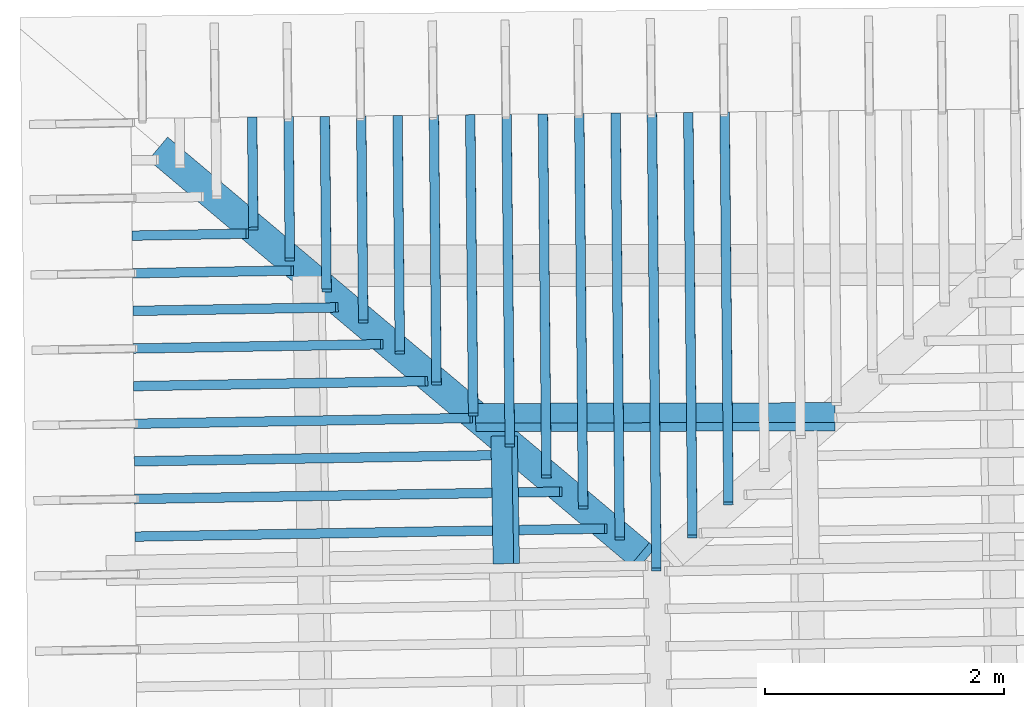
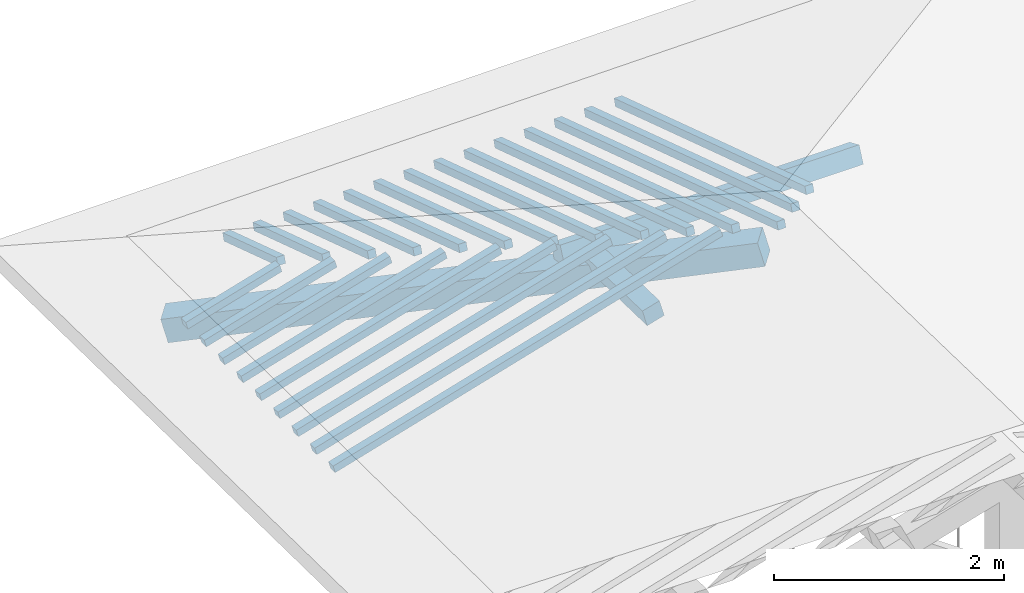
# One storey, part 7 of 19: 24 beams, 2 members, 2 elements without a shape of their own.
"""IFC4 building model written with IfcOpenShell, lengths in metres."""

from ifc_helpers import new_model, entity, si_unit, converted_unit, derived_unit, direction, frame, origin, place, context, subcontext, project, spatial, indexed_curve, outline, extrude, source, transform, mapped, material, type_object, type_shapes, element, aggregate, save


model = new_model("IFC4")

# Units and contexts
model_context = context("Model", 3, precision=1e-05, world=origin(), true_north=direction((6.123233995736766e-17, 1.0)))
body_context = subcontext(model_context, "Body", "Model", "MODEL_VIEW")
ifc_project = project(units=[si_unit("LENGTHUNIT", "METRE"), si_unit("AREAUNIT", "SQUARE_METRE"), si_unit("VOLUMEUNIT", "CUBIC_METRE"), converted_unit("PLANEANGLEUNIT", "DEGREE", entity("IfcPlaneAngleMeasure", 0.017453292519943278), si_unit("PLANEANGLEUNIT", "RADIAN"), dimensions=[0, 0, 0, 0, 0, 0, 0]), derived_unit("THERMALTRANSMITTANCEUNIT", [(si_unit("MASSUNIT", "GRAM", prefix="KILO"), 1), (si_unit("THERMODYNAMICTEMPERATUREUNIT", "KELVIN"), -1), (si_unit("TIMEUNIT", "SECOND"), -3)])], contexts=[model_context])

# Site, building, storey
site_placement = place(None, origin())
site = spatial("IfcSite", under=ifc_project, at=site_placement, CompositionType="ELEMENT")
building_placement = place(site_placement, origin())
building = spatial("IfcBuilding", under=site, at=building_placement, CompositionType="ELEMENT")
storey_placement = place(building_placement, frame((0.0, 0.0, 3.28)))
storey = spatial("IfcBuildingStorey", under=building, at=storey_placement, Name="Livello Copertura", CompositionType="ELEMENT", Elevation=3.28)

# Beam
ifc_material = material(Name="Legno - Legno da costruzione", Category="Legno")
beam_type_1 = type_object("IfcBeamType", Name="Legno:250x250", PredefinedType="BEAM", material=ifc_material)
shared_shape_1 = source(origin(), body_context, "Body", "SweptSolid", [
    extrude(outline(indexed_curve([(-0.12500000000000164, -2.7355), (0.12500000000000164, -2.7355), (0.12500000000000164, 2.7355), (-0.12500000000000164, 2.7355), (-0.12500000000000164, -2.7355)], self_intersect=False)), frame((-0.0950000000000006, 0.0, -0.1250000000000054), z_axis=(0.0, 0.0, 1.0), x_axis=(0.0, 1.0, 0.0)), (0.0, 0.0, 1.0), 0.2499999999999999),
])
type_shapes(beam_type_1, [shared_shape_1])
beam_1_placement = place(storey_placement, frame((-2.3629427365183457, 14.051413418948627, 0.36402273264411583), z_axis=(-0.2038971762637635, 0.17169897128682185, 0.963818138847112), x_axis=(0.7372422601012248, -0.6208214354317583, 0.26656067832538444)))
element("IfcBeam", 1, at=beam_1_placement, inside=storey, type_object=beam_type_1, material=ifc_material, Name="Legno:250x250", ObjectType="Legno:250x250", PredefinedType="BEAM", context=body_context, shape_type="MappedRepresentation", body=[
    mapped(shared_shape_1, transform((0.0, 0.0, 0.0), scale=1.0)),
])

# Members
member_type_1 = type_object("IfcMemberType", Name="Legno:180x180", PredefinedType="PURLIN", material=ifc_material)
shared_shape_2 = source(origin(), body_context, "Body", "SweptSolid", [
    extrude(outline(indexed_curve([(-0.5345354507284932, -0.09000000000000168), (0.5345354507284932, -0.09000000000000168), (0.5345354507284932, 0.09000000000000168), (-0.5345354507284932, 0.09000000000000168), (-0.5345354507284932, -0.09000000000000168)], self_intersect=False)), frame((1.3844645492715069, 0.0, -0.09000000000000546), z_axis=(0.0, 0.0, 1.0), x_axis=(-1.0, 0.0, 0.0)), (0.0, 0.0, 1.0), 0.17999999999999997),
])
type_shapes(member_type_1, [shared_shape_2])
member_1_placement = place(storey_placement, frame((-1.5920504501020536, 14.272503684246734, 0.7968203716684472), z_axis=(-0.2688805697492535, -0.0045944674406682715, 0.9631625667976581), x_axis=(0.017084897015610542, -0.9998540424951863, 0.0)))
element("IfcMember", 2, at=member_1_placement, inside=storey, type_object=member_type_1, material=ifc_material, Name="Legno:180x180", ObjectType="Legno:180x180", PredefinedType="PURLIN", context=body_context, shape_type="MappedRepresentation", body=[
    mapped(shared_shape_2, transform((0.0, 0.0, 0.0), scale=1.0)),
])
member_type_2 = type_object("IfcMemberType", Name="Legno:180x180", PredefinedType="PURLIN", material=ifc_material)
shared_shape_3 = source(origin(), body_context, "Body", "SweptSolid", [
    extrude(outline(indexed_curve([(-1.503167672853547, -0.09000000000000168), (1.503167672853547, -0.09000000000000168), (1.503167672853547, 0.09000000000000168), (-1.503167672853547, 0.09000000000000168), (-1.503167672853547, -0.09000000000000168)], self_intersect=False)), frame((-0.023375203311459914, 0.0, -0.09000000000000546), z_axis=(0.0, 0.0, 1.0), x_axis=(-1.0, 0.0, 0.0)), (0.0, 0.0, 1.0), 0.17999999999999997),
])
type_shapes(member_type_2, [shared_shape_3])
member_2_placement = place(storey_placement, frame((-0.288383385968343, 13.580822263893765, 0.7822739295902611), z_axis=(-0.003827735091052196, 0.39970199506726445, 0.9166371493580877), x_axis=(0.999992471364468, 0.002113791127369677, 0.0032540899577913683)))
element("IfcMember", 3, at=member_2_placement, inside=storey, type_object=member_type_2, material=ifc_material, Name="Legno:180x180", ObjectType="Legno:180x180", PredefinedType="PURLIN", context=body_context, shape_type="MappedRepresentation", body=[
    mapped(shared_shape_3, transform((0.0, 0.0, 0.0), scale=1.0)),
])

# Assembly, beams
assembly_1_placement = place(storey_placement, origin())
assembly_1 = element("IfcElementAssembly", 4, at=assembly_1_placement, inside=storey, Name="Sistema di travi strutturali:Sistema di travi strutturali", ObjectType="Sistema di travi strutturali:Sistema di travi strutturali", AssemblyPlace="NOTDEFINED", PredefinedType="BEAM_GRID")
beam_type_2 = type_object("IfcBeamType", Name="Legno:80x80", PredefinedType="JOIST", material=ifc_material)
shared_shape_4 = source(origin(), body_context, "Body", "SweptSolid", [
    extrude(outline(indexed_curve([(-0.49550000000000005, -0.04000000000000169), (0.49550000000000005, -0.04000000000000169), (0.49550000000000005, 0.04000000000000169), (-0.49550000000000005, 0.04000000000000169), (-0.49550000000000005, -0.04000000000000169)], self_intersect=False)), frame((0.0, 0.0, -0.040000000000005476), z_axis=(0.0, 0.0, 1.0), x_axis=(-1.0, 0.0, 0.0)), (0.0, 0.0, 1.0), 0.07999999999999997),
])
type_shapes(beam_type_2, [shared_shape_4])
beam_2_placement = place(assembly_1_placement, frame((-4.204275399686533, 15.108842320098882, 0.24786585234562697), z_axis=(-0.2688805697492536, -0.004594467440668277, 0.9631625667976582), x_axis=(0.9630219859926786, 0.016455533263025738, 0.26891982061526554)))
beam_2 = element("IfcBeam", 5, at=beam_2_placement, type_object=beam_type_2, material=ifc_material, Name="Legno:80x80", ObjectType="Legno:80x80", PredefinedType="JOIST", context=body_context, shape_type="MappedRepresentation", body=[
    mapped(shared_shape_4, transform((0.0, 0.0, 0.0), scale=1.0)),
])
beam_type_3 = type_object("IfcBeamType", Name="Legno:80x80", PredefinedType="JOIST", material=ifc_material)
shared_shape_5 = source(origin(), body_context, "Body", "SweptSolid", [
    extrude(outline(indexed_curve([(-0.6885, -0.04000000000000169), (0.6885, -0.04000000000000169), (0.6885, 0.04000000000000169), (-0.6885, 0.04000000000000169), (-0.6885, -0.04000000000000169)], self_intersect=False)), frame((0.0, 0.0, -0.040000000000005476), z_axis=(0.0, 0.0, 1.0), x_axis=(-1.0, 0.0, 0.0)), (0.0, 0.0, 1.0), 0.07999999999999997),
])
type_shapes(beam_type_3, [shared_shape_5])
beam_3_placement = place(assembly_1_placement, frame((-4.01528613206869, 14.797025670293023, 0.2991374779371173), z_axis=(-0.26888056974925334, -0.004594467440668276, 0.9631625667976583), x_axis=(0.9630219859926787, 0.016455533263026557, 0.2689198206152653)))
beam_3 = element("IfcBeam", 6, at=beam_3_placement, type_object=beam_type_3, material=ifc_material, Name="Legno:80x80", ObjectType="Legno:80x80", PredefinedType="JOIST", context=body_context, shape_type="MappedRepresentation", body=[
    mapped(shared_shape_5, transform((0.0, 0.0, 0.0), scale=1.0)),
])
beam_type_4 = type_object("IfcBeamType", Name="Legno:80x80", PredefinedType="JOIST", material=ifc_material)
shared_shape_6 = source(origin(), body_context, "Body", "SweptSolid", [
    extrude(outline(indexed_curve([(-0.8815000000000001, -0.04000000000000169), (0.8815000000000001, -0.04000000000000169), (0.8815000000000001, 0.04000000000000169), (-0.8815000000000001, 0.04000000000000169), (-0.8815000000000001, -0.04000000000000169)], self_intersect=False)), frame((0.0, 0.0, -0.040000000000005476), z_axis=(0.0, 0.0, 1.0), x_axis=(-1.0, 0.0, 0.0)), (0.0, 0.0, 1.0), 0.07999999999999997),
])
type_shapes(beam_type_4, [shared_shape_6])
beam_4_placement = place(assembly_1_placement, frame((-3.826296864450847, 14.485209020487163, 0.35040910352860777), z_axis=(-0.26888056974925334, -0.004594467440668277, 0.9631625667976583), x_axis=(0.9630219859926787, 0.016455533263027, 0.26891982061526526)))
beam_4 = element("IfcBeam", 7, at=beam_4_placement, type_object=beam_type_4, material=ifc_material, Name="Legno:80x80", ObjectType="Legno:80x80", PredefinedType="JOIST", context=body_context, shape_type="MappedRepresentation", body=[
    mapped(shared_shape_6, transform((0.0, 0.0, 0.0), scale=1.0)),
])
beam_type_5 = type_object("IfcBeamType", Name="Legno:80x80", PredefinedType="JOIST", material=ifc_material)
shared_shape_7 = source(origin(), body_context, "Body", "SweptSolid", [
    extrude(outline(indexed_curve([(-1.0745, -0.04000000000000169), (1.0745, -0.04000000000000169), (1.0745, 0.04000000000000169), (-1.0745, 0.04000000000000169), (-1.0745, -0.04000000000000169)], self_intersect=False)), frame((0.0, 0.0, -0.040000000000005476), z_axis=(0.0, 0.0, 1.0), x_axis=(-1.0, 0.0, 0.0)), (0.0, 0.0, 1.0), 0.07999999999999997),
])
type_shapes(beam_type_5, [shared_shape_7])
beam_5_placement = place(assembly_1_placement, frame((-3.6373075968330033, 14.173392370681299, 0.4016807291200988), z_axis=(-0.2688805697492536, -0.004594467440668275, 0.9631625667976583), x_axis=(0.9630219859926786, 0.01645553326302628, 0.26891982061526554)))
beam_5 = element("IfcBeam", 8, at=beam_5_placement, type_object=beam_type_5, material=ifc_material, Name="Legno:80x80", ObjectType="Legno:80x80", PredefinedType="JOIST", context=body_context, shape_type="MappedRepresentation", body=[
    mapped(shared_shape_7, transform((0.0, 0.0, 0.0), scale=1.0)),
])
beam_type_6 = type_object("IfcBeamType", Name="Legno:80x80", PredefinedType="JOIST", material=ifc_material)
shared_shape_8 = source(origin(), body_context, "Body", "SweptSolid", [
    extrude(outline(indexed_curve([(-1.2675, -0.04000000000000169), (1.2675, -0.04000000000000169), (1.2675, 0.04000000000000169), (-1.2675, 0.04000000000000169), (-1.2675, -0.04000000000000169)], self_intersect=False)), frame((0.0, 0.0, -0.040000000000005476), z_axis=(0.0, 0.0, 1.0), x_axis=(-1.0, 0.0, 0.0)), (0.0, 0.0, 1.0), 0.07999999999999997),
])
type_shapes(beam_type_6, [shared_shape_8])
beam_6_placement = place(assembly_1_placement, frame((-3.4483183292151605, 13.861575720875445, 0.4529523547115888), z_axis=(-0.2688805697492534, -0.004594467440668276, 0.9631625667976583), x_axis=(0.9630219859926786, 0.016455533263026643, 0.2689198206152653)))
beam_6 = element("IfcBeam", 9, at=beam_6_placement, type_object=beam_type_6, material=ifc_material, Name="Legno:80x80", ObjectType="Legno:80x80", PredefinedType="JOIST", context=body_context, shape_type="MappedRepresentation", body=[
    mapped(shared_shape_8, transform((0.0, 0.0, 0.0), scale=1.0)),
])
beam_type_7 = type_object("IfcBeamType", Name="Legno:80x80", PredefinedType="JOIST", material=ifc_material)
shared_shape_9 = source(origin(), body_context, "Body", "SweptSolid", [
    extrude(outline(indexed_curve([(-1.4605000000000001, -0.04000000000000169), (1.4605000000000001, -0.04000000000000169), (1.4605000000000001, 0.04000000000000169), (-1.4605000000000001, 0.04000000000000169), (-1.4605000000000001, -0.04000000000000169)], self_intersect=False)), frame((0.0, 0.0, -0.040000000000005476), z_axis=(0.0, 0.0, 1.0), x_axis=(-1.0, 0.0, 0.0)), (0.0, 0.0, 1.0), 0.07999999999999997),
])
type_shapes(beam_type_7, [shared_shape_9])
beam_7_placement = place(assembly_1_placement, frame((-3.2593290615973176, 13.549759071069586, 0.5042239803030794), z_axis=(-0.26888056974925334, -0.004594467440668277, 0.9631625667976583), x_axis=(0.9630219859926787, 0.01645553326302691, 0.26891982061526526)))
beam_7 = element("IfcBeam", 10, at=beam_7_placement, type_object=beam_type_7, material=ifc_material, Name="Legno:80x80", ObjectType="Legno:80x80", PredefinedType="JOIST", context=body_context, shape_type="MappedRepresentation", body=[
    mapped(shared_shape_9, transform((0.0, 0.0, 0.0), scale=1.0)),
])
beam_type_8 = type_object("IfcBeamType", Name="Legno:80x80", PredefinedType="JOIST", material=ifc_material)
shared_shape_10 = source(origin(), body_context, "Body", "SweptSolid", [
    extrude(outline(indexed_curve([(-1.6540000000000001, -0.04000000000000169), (1.6540000000000001, -0.04000000000000169), (1.6540000000000001, 0.04000000000000169), (-1.6540000000000001, 0.04000000000000169), (-1.6540000000000001, -0.04000000000000169)], self_intersect=False)), frame((0.0, 0.0, -0.040000000000005476), z_axis=(0.0, 0.0, 1.0), x_axis=(-1.0, 0.0, 0.0)), (0.0, 0.0, 1.0), 0.07999999999999997),
])
type_shapes(beam_type_8, [shared_shape_10])
beam_8_placement = place(assembly_1_placement, frame((-3.0703397939794743, 13.237942421263726, 0.5554956058945699), z_axis=(-0.26888056974925345, -0.0045944674406682776, 0.9631625667976583), x_axis=(0.9630219859926786, 0.016455533263027105, 0.26891982061526537)))
beam_8 = element("IfcBeam", 11, at=beam_8_placement, type_object=beam_type_8, material=ifc_material, Name="Legno:80x80", ObjectType="Legno:80x80", PredefinedType="JOIST", context=body_context, shape_type="MappedRepresentation", body=[
    mapped(shared_shape_10, transform((0.0, 0.0, 0.0), scale=1.0)),
])
beam_type_9 = type_object("IfcBeamType", Name="Legno:80x80", PredefinedType="JOIST", material=ifc_material)
shared_shape_11 = source(origin(), body_context, "Body", "SweptSolid", [
    extrude(outline(indexed_curve([(-1.847, -0.04000000000000169), (1.847, -0.04000000000000169), (1.847, 0.04000000000000169), (-1.847, 0.04000000000000169), (-1.847, -0.04000000000000169)], self_intersect=False)), frame((0.0, 0.0, -0.040000000000005476), z_axis=(0.0, 0.0, 1.0), x_axis=(-1.0, 0.0, 0.0)), (0.0, 0.0, 1.0), 0.07999999999999997),
])
type_shapes(beam_type_9, [shared_shape_11])
beam_9_placement = place(assembly_1_placement, frame((-2.881350526361631, 12.92612577145787, 0.6067672314860602), z_axis=(-0.26888056974925345, -0.004594467440668277, 0.9631625667976582), x_axis=(0.9630219859926786, 0.01645553326302668, 0.26891982061526537)))
beam_9 = element("IfcBeam", 12, at=beam_9_placement, type_object=beam_type_9, material=ifc_material, Name="Legno:80x80", ObjectType="Legno:80x80", PredefinedType="JOIST", context=body_context, shape_type="MappedRepresentation", body=[
    mapped(shared_shape_11, transform((0.0, 0.0, 0.0), scale=1.0)),
])
beam_type_10 = type_object("IfcBeamType", Name="Legno:80x80", PredefinedType="JOIST", material=ifc_material)
shared_shape_12 = source(origin(), body_context, "Body", "SweptSolid", [
    extrude(outline(indexed_curve([(-2.04, -0.04000000000000169), (2.04, -0.04000000000000169), (2.04, 0.04000000000000169), (-2.04, 0.04000000000000169), (-2.04, -0.04000000000000169)], self_intersect=False)), frame((0.0, 0.0, -0.040000000000005476), z_axis=(0.0, 0.0, 1.0), x_axis=(-1.0, 0.0, 0.0)), (0.0, 0.0, 1.0), 0.07999999999999997),
])
type_shapes(beam_type_10, [shared_shape_12])
beam_10_placement = place(assembly_1_placement, frame((-2.6923612587437877, 12.614309121652008, 0.6580388570775514), z_axis=(-0.2688805697492535, -0.004594467440668277, 0.9631625667976583), x_axis=(0.9630219859926786, 0.016455533263026862, 0.2689198206152654)))
beam_10 = element("IfcBeam", 13, at=beam_10_placement, type_object=beam_type_10, material=ifc_material, Name="Legno:80x80", ObjectType="Legno:80x80", PredefinedType="JOIST", context=body_context, shape_type="MappedRepresentation", body=[
    mapped(shared_shape_12, transform((0.0, 0.0, 0.0), scale=1.0)),
])
aggregate(assembly_1, [beam_2, beam_3, beam_4, beam_5, beam_6, beam_7, beam_8, beam_9, beam_10])

assembly_2_placement = place(storey_placement, origin())
assembly_2 = element("IfcElementAssembly", 14, at=assembly_2_placement, inside=storey, Name="Sistema di travi strutturali:Sistema di travi strutturali", ObjectType="Sistema di travi strutturali:Sistema di travi strutturali", AssemblyPlace="NOTDEFINED", PredefinedType="BEAM_GRID")
beam_type_11 = type_object("IfcBeamType", Name="Legno:80x80", PredefinedType="JOIST", material=ifc_material)
shared_shape_13 = source(origin(), body_context, "Body", "SweptSolid", [
    extrude(outline(indexed_curve([(-0.4835, -0.04000000000000169), (0.4835, -0.04000000000000169), (0.4835, 0.04000000000000169), (-0.4835, 0.04000000000000169), (-0.4835, -0.04000000000000169)], self_intersect=False)), frame((0.0, 0.0, -0.040000000000005476), z_axis=(0.0, 0.0, 1.0), x_axis=(-1.0, 0.0, 0.0)), (0.0, 0.0, 1.0), 0.07999999999999997),
])
type_shapes(beam_type_11, [shared_shape_13])
beam_11_placement = place(assembly_2_placement, frame((-3.682268254102384, 15.619999952082669, 0.2526134403773561), z_axis=(-0.0071866559421429384, 0.3016187585889338, 0.9534015294951229), x_axis=(0.009276659863625808, -0.9533650144726799, 0.30167713330857837)))
beam_11 = element("IfcBeam", 15, at=beam_11_placement, type_object=beam_type_11, material=ifc_material, Name="Legno:80x80", ObjectType="Legno:80x80", PredefinedType="JOIST", context=body_context, shape_type="MappedRepresentation", body=[
    mapped(shared_shape_13, transform((0.0, 0.0, 0.0), scale=1.0)),
])
beam_type_12 = type_object("IfcBeamType", Name="Legno:80x80", PredefinedType="JOIST", material=ifc_material)
shared_shape_14 = source(origin(), body_context, "Body", "SweptSolid", [
    extrude(outline(indexed_curve([(-0.621, -0.04000000000000169), (0.621, -0.04000000000000169), (0.621, 0.04000000000000169), (-0.621, 0.04000000000000169), (-0.621, -0.04000000000000169)], self_intersect=False)), frame((0.0, 0.0, -0.040000000000005476), z_axis=(0.0, 0.0, 1.0), x_axis=(-1.0, 0.0, 0.0)), (0.0, 0.0, 1.0), 0.07999999999999997),
])
type_shapes(beam_type_12, [shared_shape_14])
beam_12_placement = place(assembly_2_placement, frame((-3.376710203100349, 15.49190748044935, 0.2954401315440407), z_axis=(-0.007186655942142943, 0.30161875858893417, 0.9534015294951228), x_axis=(0.009276659863625684, -0.9533650144726797, 0.30167713330857876)))
beam_12 = element("IfcBeam", 16, at=beam_12_placement, type_object=beam_type_12, material=ifc_material, Name="Legno:80x80", ObjectType="Legno:80x80", PredefinedType="JOIST", context=body_context, shape_type="MappedRepresentation", body=[
    mapped(shared_shape_14, transform((0.0, 0.0, 0.0), scale=1.0)),
])
beam_type_13 = type_object("IfcBeamType", Name="Legno:80x80", PredefinedType="JOIST", material=ifc_material)
shared_shape_15 = source(origin(), body_context, "Body", "SweptSolid", [
    extrude(outline(indexed_curve([(-0.759, -0.04000000000000169), (0.759, -0.04000000000000169), (0.759, 0.04000000000000169), (-0.759, 0.04000000000000169), (-0.759, -0.04000000000000169)], self_intersect=False)), frame((0.0, 0.0, -0.040000000000005476), z_axis=(0.0, 0.0, 1.0), x_axis=(-1.0, 0.0, 0.0)), (0.0, 0.0, 1.0), 0.07999999999999997),
])
type_shapes(beam_type_13, [shared_shape_15])
beam_13_placement = place(assembly_2_placement, frame((-3.071152152098315, 15.363815008816031, 0.3382668227107253), z_axis=(-0.007186655942142942, 0.30161875858893405, 0.9534015294951229), x_axis=(0.009276659863625608, -0.9533650144726797, 0.30167713330857865)))
beam_13 = element("IfcBeam", 17, at=beam_13_placement, type_object=beam_type_13, material=ifc_material, Name="Legno:80x80", ObjectType="Legno:80x80", PredefinedType="JOIST", context=body_context, shape_type="MappedRepresentation", body=[
    mapped(shared_shape_15, transform((0.0, 0.0, 0.0), scale=1.0)),
])
beam_type_14 = type_object("IfcBeamType", Name="Legno:80x80", PredefinedType="JOIST", material=ifc_material)
shared_shape_16 = source(origin(), body_context, "Body", "SweptSolid", [
    extrude(outline(indexed_curve([(-0.8970000000000001, -0.04000000000000169), (0.8970000000000001, -0.04000000000000169), (0.8970000000000001, 0.04000000000000169), (-0.8970000000000001, 0.04000000000000169), (-0.8970000000000001, -0.04000000000000169)], self_intersect=False)), frame((0.0, 0.0, -0.040000000000005476), z_axis=(0.0, 0.0, 1.0), x_axis=(-1.0, 0.0, 0.0)), (0.0, 0.0, 1.0), 0.07999999999999997),
])
type_shapes(beam_type_14, [shared_shape_16])
beam_14_placement = place(assembly_2_placement, frame((-2.7655941010962777, 15.235722537182715, 0.3810935138774125), z_axis=(-0.007186655942142938, 0.30161875858893356, 0.953401529495123), x_axis=(0.009276659863625532, -0.95336501447268, 0.30167713330857815)))
beam_14 = element("IfcBeam", 18, at=beam_14_placement, type_object=beam_type_14, material=ifc_material, Name="Legno:80x80", ObjectType="Legno:80x80", PredefinedType="JOIST", context=body_context, shape_type="MappedRepresentation", body=[
    mapped(shared_shape_16, transform((0.0, 0.0, 0.0), scale=1.0)),
])
beam_type_15 = type_object("IfcBeamType", Name="Legno:80x80", PredefinedType="JOIST", material=ifc_material)
shared_shape_17 = source(origin(), body_context, "Body", "SweptSolid", [
    extrude(outline(indexed_curve([(-1.035, -0.04000000000000169), (1.035, -0.04000000000000169), (1.035, 0.04000000000000169), (-1.035, 0.04000000000000169), (-1.035, -0.04000000000000169)], self_intersect=False)), frame((0.0, 0.0, -0.040000000000005476), z_axis=(0.0, 0.0, 1.0), x_axis=(-1.0, 0.0, 0.0)), (0.0, 0.0, 1.0), 0.07999999999999997),
])
type_shapes(beam_type_15, [shared_shape_17])
beam_15_placement = place(assembly_2_placement, frame((-2.460036050094243, 15.1076300655494, 0.42392020504409533), z_axis=(-0.00718665594214294, 0.3016187585889339, 0.9534015294951229), x_axis=(0.009276659863625768, -0.9533650144726799, 0.3016771333085785)))
beam_15 = element("IfcBeam", 19, at=beam_15_placement, type_object=beam_type_15, material=ifc_material, Name="Legno:80x80", ObjectType="Legno:80x80", PredefinedType="JOIST", context=body_context, shape_type="MappedRepresentation", body=[
    mapped(shared_shape_17, transform((0.0, 0.0, 0.0), scale=1.0)),
])
beam_type_16 = type_object("IfcBeamType", Name="Legno:80x80", PredefinedType="JOIST", material=ifc_material)
shared_shape_18 = source(origin(), body_context, "Body", "SweptSolid", [
    extrude(outline(indexed_curve([(-1.1724999999999999, -0.04000000000000169), (1.1724999999999999, -0.04000000000000169), (1.1724999999999999, 0.04000000000000169), (-1.1724999999999999, 0.04000000000000169), (-1.1724999999999999, -0.04000000000000169)], self_intersect=False)), frame((0.0, 0.0, -0.040000000000005476), z_axis=(0.0, 0.0, 1.0), x_axis=(-1.0, 0.0, 0.0)), (0.0, 0.0, 1.0), 0.07999999999999997),
])
type_shapes(beam_type_16, [shared_shape_18])
beam_16_placement = place(assembly_2_placement, frame((-2.1544779990922076, 14.979537593916083, 0.4667468962107799), z_axis=(-0.0071866559421429384, 0.3016187585889338, 0.9534015294951229), x_axis=(0.009276659863625698, -0.9533650144726799, 0.30167713330857837)))
beam_16 = element("IfcBeam", 20, at=beam_16_placement, type_object=beam_type_16, material=ifc_material, Name="Legno:80x80", ObjectType="Legno:80x80", PredefinedType="JOIST", context=body_context, shape_type="MappedRepresentation", body=[
    mapped(shared_shape_18, transform((0.0, 0.0, 0.0), scale=1.0)),
])
beam_type_17 = type_object("IfcBeamType", Name="Legno:80x80", PredefinedType="JOIST", material=ifc_material)
shared_shape_19 = source(origin(), body_context, "Body", "SweptSolid", [
    extrude(outline(indexed_curve([(-1.3105000000000002, -0.04000000000000169), (1.3105000000000002, -0.04000000000000169), (1.3105000000000002, 0.04000000000000169), (-1.3105000000000002, 0.04000000000000169), (-1.3105000000000002, -0.04000000000000169)], self_intersect=False)), frame((0.0, 0.0, -0.040000000000005476), z_axis=(0.0, 0.0, 1.0), x_axis=(-1.0, 0.0, 0.0)), (0.0, 0.0, 1.0), 0.07999999999999997),
])
type_shapes(beam_type_17, [shared_shape_19])
beam_17_placement = place(assembly_2_placement, frame((-1.8489199480901715, 14.851445122282763, 0.5095735873774663), z_axis=(-0.007186655942142939, 0.3016187585889337, 0.953401529495123), x_axis=(0.009276659863625651, -0.9533650144726797, 0.30167713330857837)))
beam_17 = element("IfcBeam", 21, at=beam_17_placement, type_object=beam_type_17, material=ifc_material, Name="Legno:80x80", ObjectType="Legno:80x80", PredefinedType="JOIST", context=body_context, shape_type="MappedRepresentation", body=[
    mapped(shared_shape_19, transform((0.0, 0.0, 0.0), scale=1.0)),
])
beam_type_18 = type_object("IfcBeamType", Name="Legno:80x80", PredefinedType="JOIST", material=ifc_material)
shared_shape_20 = source(origin(), body_context, "Body", "SweptSolid", [
    extrude(outline(indexed_curve([(-1.4485000000000001, -0.04000000000000169), (1.4485000000000001, -0.04000000000000169), (1.4485000000000001, 0.04000000000000169), (-1.4485000000000001, 0.04000000000000169), (-1.4485000000000001, -0.04000000000000169)], self_intersect=False)), frame((0.0, 0.0, -0.040000000000005476), z_axis=(0.0, 0.0, 1.0), x_axis=(-1.0, 0.0, 0.0)), (0.0, 0.0, 1.0), 0.07999999999999997),
])
type_shapes(beam_type_18, [shared_shape_20])
beam_18_placement = place(assembly_2_placement, frame((-1.5433618970881364, 14.72335265064945, 0.5524002785441491), z_axis=(-0.007186655942142937, 0.30161875858893356, 0.953401529495123), x_axis=(0.00927665986362561, -0.95336501447268, 0.30167713330857815)))
beam_18 = element("IfcBeam", 22, at=beam_18_placement, type_object=beam_type_18, material=ifc_material, Name="Legno:80x80", ObjectType="Legno:80x80", PredefinedType="JOIST", context=body_context, shape_type="MappedRepresentation", body=[
    mapped(shared_shape_20, transform((0.0, 0.0, 0.0), scale=1.0)),
])
beam_type_19 = type_object("IfcBeamType", Name="Legno:80x80", PredefinedType="JOIST", material=ifc_material)
shared_shape_21 = source(origin(), body_context, "Body", "SweptSolid", [
    extrude(outline(indexed_curve([(-1.586, -0.04000000000000169), (1.586, -0.04000000000000169), (1.586, 0.04000000000000169), (-1.586, 0.04000000000000169), (-1.586, -0.04000000000000169)], self_intersect=False)), frame((0.0, 0.0, -0.040000000000005476), z_axis=(0.0, 0.0, 1.0), x_axis=(-1.0, 0.0, 0.0)), (0.0, 0.0, 1.0), 0.07999999999999997),
])
type_shapes(beam_type_19, [shared_shape_21])
beam_19_placement = place(assembly_2_placement, frame((-1.237803846086101, 14.59526017901613, 0.5952269697108354), z_axis=(-0.00718665594214294, 0.3016187585889339, 0.9534015294951229), x_axis=(0.009276659863625669, -0.9533650144726799, 0.3016771333085785)))
beam_19 = element("IfcBeam", 23, at=beam_19_placement, type_object=beam_type_19, material=ifc_material, Name="Legno:80x80", ObjectType="Legno:80x80", PredefinedType="JOIST", context=body_context, shape_type="MappedRepresentation", body=[
    mapped(shared_shape_21, transform((0.0, 0.0, 0.0), scale=1.0)),
])
beam_type_20 = type_object("IfcBeamType", Name="Legno:80x80", PredefinedType="JOIST", material=ifc_material)
shared_shape_22 = source(origin(), body_context, "Body", "SweptSolid", [
    extrude(outline(indexed_curve([(-1.7240000000000002, -0.04000000000000169), (1.7240000000000002, -0.04000000000000169), (1.7240000000000002, 0.04000000000000169), (-1.7240000000000002, 0.04000000000000169), (-1.7240000000000002, -0.04000000000000169)], self_intersect=False)), frame((0.0, 0.0, -0.040000000000005476), z_axis=(0.0, 0.0, 1.0), x_axis=(-1.0, 0.0, 0.0)), (0.0, 0.0, 1.0), 0.07999999999999997),
])
type_shapes(beam_type_20, [shared_shape_22])
beam_20_placement = place(assembly_2_placement, frame((-0.932245795084066, 14.467167707382819, 0.6380536608775218), z_axis=(-0.007186655942142938, 0.3016187585889337, 0.953401529495123), x_axis=(0.00927665986362563, -0.9533650144726799, 0.3016771333085783)))
beam_20 = element("IfcBeam", 24, at=beam_20_placement, type_object=beam_type_20, material=ifc_material, Name="Legno:80x80", ObjectType="Legno:80x80", PredefinedType="JOIST", context=body_context, shape_type="MappedRepresentation", body=[
    mapped(shared_shape_22, transform((0.0, 0.0, 0.0), scale=1.0)),
])
beam_type_21 = type_object("IfcBeamType", Name="Legno:80x80", PredefinedType="JOIST", material=ifc_material)
shared_shape_23 = source(origin(), body_context, "Body", "SweptSolid", [
    extrude(outline(indexed_curve([(-1.862, -0.04000000000000169), (1.862, -0.04000000000000169), (1.862, 0.04000000000000169), (-1.862, 0.04000000000000169), (-1.862, -0.04000000000000169)], self_intersect=False)), frame((0.0, 0.0, -0.040000000000005476), z_axis=(0.0, 0.0, 1.0), x_axis=(-1.0, 0.0, 0.0)), (0.0, 0.0, 1.0), 0.07999999999999997),
])
type_shapes(beam_type_21, [shared_shape_23])
beam_21_placement = place(assembly_2_placement, frame((-0.6266877440820298, 14.339075235749497, 0.6808803520442055), z_axis=(-0.0071866559421429384, 0.3016187585889336, 0.953401529495123), x_axis=(0.009276659863625634, -0.9533650144726797, 0.30167713330857826)))
beam_21 = element("IfcBeam", 25, at=beam_21_placement, type_object=beam_type_21, material=ifc_material, Name="Legno:80x80", ObjectType="Legno:80x80", PredefinedType="JOIST", context=body_context, shape_type="MappedRepresentation", body=[
    mapped(shared_shape_23, transform((0.0, 0.0, 0.0), scale=1.0)),
])
beam_type_22 = type_object("IfcBeamType", Name="Legno:80x80", PredefinedType="JOIST", material=ifc_material)
shared_shape_24 = source(origin(), body_context, "Body", "SweptSolid", [
    extrude(outline(indexed_curve([(-2.0, -0.04000000000000169), (2.0, -0.04000000000000169), (2.0, 0.04000000000000169), (-2.0, 0.04000000000000169), (-2.0, -0.04000000000000169)], self_intersect=False)), frame((0.0, 0.0, -0.040000000000005476), z_axis=(0.0, 0.0, 1.0), x_axis=(-1.0, 0.0, 0.0)), (0.0, 0.0, 1.0), 0.07999999999999997),
])
type_shapes(beam_type_22, [shared_shape_24])
beam_22_placement = place(assembly_2_placement, frame((-0.3211296930799944, 14.210982764116181, 0.7237070432108892), z_axis=(-0.0071866559421429384, 0.3016187585889338, 0.9534015294951229), x_axis=(0.009276659863625646, -0.9533650144726799, 0.30167713330857837)))
beam_22 = element("IfcBeam", 26, at=beam_22_placement, type_object=beam_type_22, material=ifc_material, Name="Legno:80x80", ObjectType="Legno:80x80", PredefinedType="JOIST", context=body_context, shape_type="MappedRepresentation", body=[
    mapped(shared_shape_24, transform((0.0, 0.0, 0.0), scale=1.0)),
])
beam_type_23 = type_object("IfcBeamType", Name="Legno:80x80", PredefinedType="JOIST", material=ifc_material)
shared_shape_25 = source(origin(), body_context, "Body", "SweptSolid", [
    extrude(outline(indexed_curve([(-1.856, -0.04000000000000169), (1.856, -0.04000000000000169), (1.856, 0.04000000000000169), (-1.856, 0.04000000000000169), (-1.856, -0.04000000000000169)], self_intersect=False)), frame((0.0, 0.0, -0.040000000000005476), z_axis=(0.0, 0.0, 1.0), x_axis=(-1.0, 0.0, 0.0)), (0.0, 0.0, 1.0), 0.07999999999999997),
])
type_shapes(beam_type_23, [shared_shape_25])
beam_23_placement = place(assembly_2_placement, frame((-0.01818453763944125, 14.351418324275336, 0.6815623271889475), z_axis=(-0.007186655942142935, 0.3016187585889335, 0.953401529495123), x_axis=(0.009276659863625636, -0.95336501447268, 0.3016771333085781)))
beam_23 = element("IfcBeam", 27, at=beam_23_placement, type_object=beam_type_23, material=ifc_material, Name="Legno:80x80", ObjectType="Legno:80x80", PredefinedType="JOIST", context=body_context, shape_type="MappedRepresentation", body=[
    mapped(shared_shape_25, transform((0.0, 0.0, 0.0), scale=1.0)),
])
beam_type_24 = type_object("IfcBeamType", Name="Legno:80x80", PredefinedType="JOIST", material=ifc_material)
shared_shape_26 = source(origin(), body_context, "Body", "SweptSolid", [
    extrude(outline(indexed_curve([(-1.7125, -0.04000000000000169), (1.7125, -0.04000000000000169), (1.7125, 0.04000000000000169), (-1.7125, 0.04000000000000169), (-1.7125, -0.04000000000000169)], self_intersect=False)), frame((0.0, 0.0, -0.040000000000005476), z_axis=(0.0, 0.0, 1.0), x_axis=(-1.0, 0.0, 0.0)), (0.0, 0.0, 1.0), 0.07999999999999997),
])
type_shapes(beam_type_24, [shared_shape_26])
beam_24_placement = place(assembly_2_placement, frame((0.28476061780111295, 14.491853884434496, 0.6394176111670076), z_axis=(-0.007186655942142937, 0.30161875858893356, 0.953401529495123), x_axis=(0.00927665986362564, -0.95336501447268, 0.30167713330857815)))
beam_24 = element("IfcBeam", 28, at=beam_24_placement, type_object=beam_type_24, material=ifc_material, Name="Legno:80x80", ObjectType="Legno:80x80", PredefinedType="JOIST", context=body_context, shape_type="MappedRepresentation", body=[
    mapped(shared_shape_26, transform((0.0, 0.0, 0.0), scale=1.0)),
])
aggregate(assembly_2, [beam_11, beam_12, beam_13, beam_14, beam_15, beam_16, beam_17, beam_18, beam_19, beam_20, beam_21, beam_22, beam_23, beam_24])

save(model, "model.ifc")
